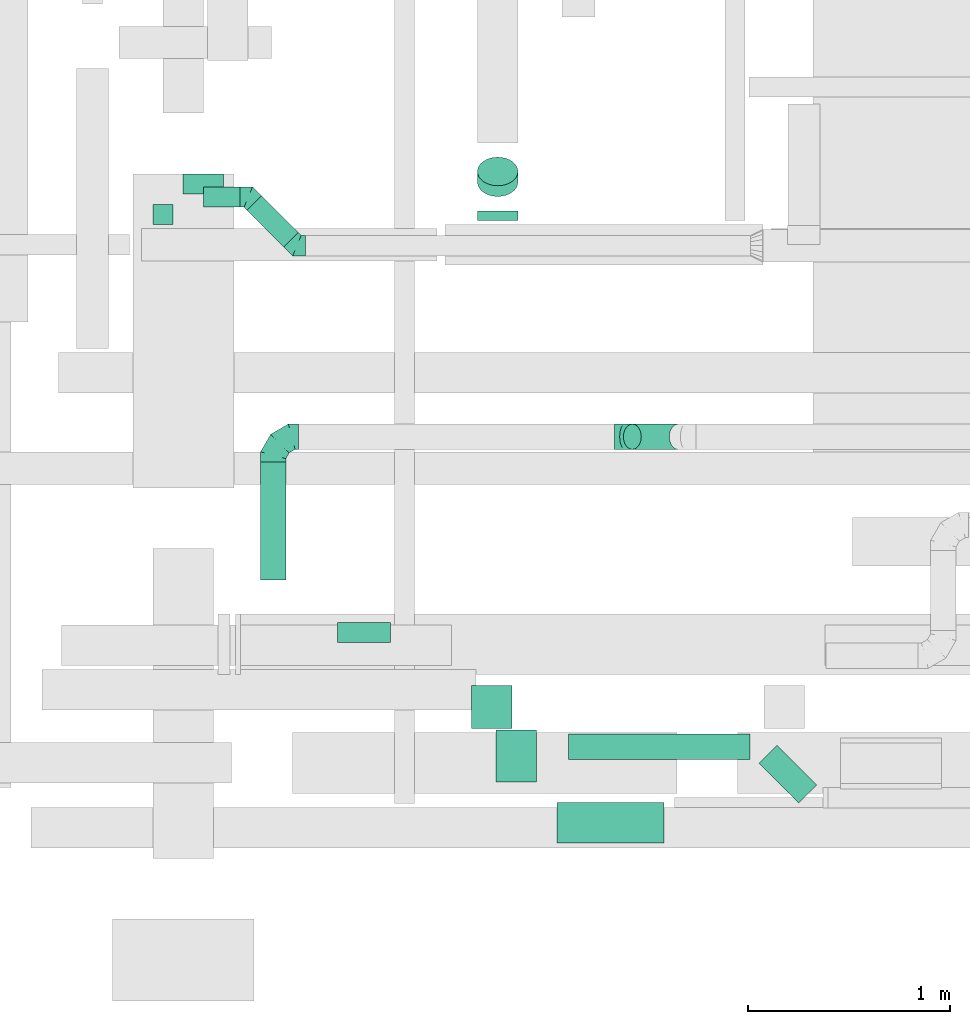
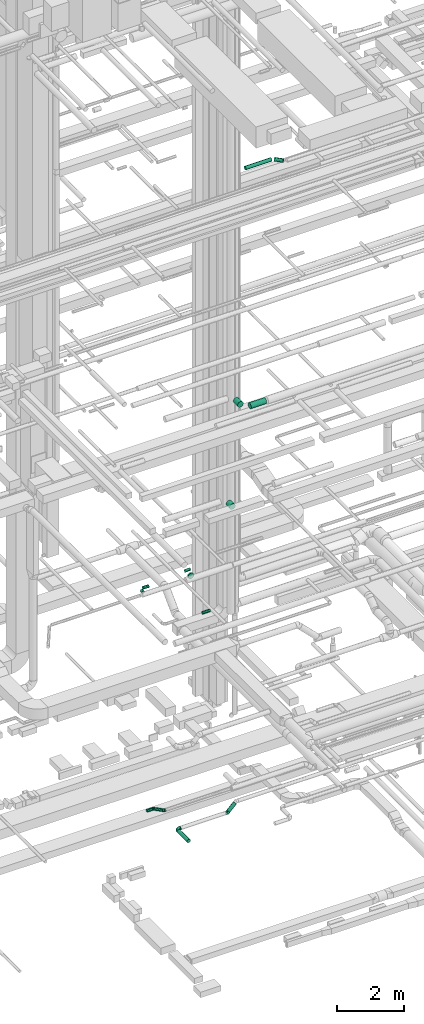
# One storey, part 114 of 337: 14 flow segments, 4 flow fittings.
"""IFC2X3 building model written with IfcOpenShell, lengths in millimetres."""

from ifc_helpers import new_model, entity, si_unit, converted_unit, derived_unit, direction, frame, origin, origin_2d_with_axis, place, context, subcontext, project, spatial, circle, extrude, faceted_brep, source, transform, mapped, material, type_object, type_shapes, element, save


model = new_model("IFC2X3")

# Units and contexts
model_context = context("Model", 3, precision=0.01, world=origin(), true_north=direction((6.12303176911189e-17, 1.0)))
body_context = subcontext(model_context, "Body", "Model", "MODEL_VIEW")
ifc_project = project(units=[si_unit("LENGTHUNIT", "METRE", prefix="MILLI"), si_unit("AREAUNIT", "SQUARE_METRE"), si_unit("VOLUMEUNIT", "CUBIC_METRE"), converted_unit("PLANEANGLEUNIT", "DEGREE", entity("IfcRatioMeasure", 0.0174532925199433), si_unit("PLANEANGLEUNIT", "RADIAN"), dimensions=[0, 0, 0, 0, 0, 0, 0]), si_unit("MASSUNIT", "GRAM", prefix="KILO"), derived_unit("MASSDENSITYUNIT", [(si_unit("MASSUNIT", "GRAM", prefix="KILO"), 1), (si_unit("LENGTHUNIT", "METRE"), -3)]), derived_unit("MOMENTOFINERTIAUNIT", [(si_unit("LENGTHUNIT", "METRE"), 4)]), si_unit("TIMEUNIT", "SECOND"), si_unit("FREQUENCYUNIT", "HERTZ"), si_unit("THERMODYNAMICTEMPERATUREUNIT", "DEGREE_CELSIUS"), derived_unit("THERMALTRANSMITTANCEUNIT", [(si_unit("MASSUNIT", "GRAM", prefix="KILO"), 1), (si_unit("THERMODYNAMICTEMPERATUREUNIT", "KELVIN"), -1), (si_unit("TIMEUNIT", "SECOND"), -3)]), derived_unit("VOLUMETRICFLOWRATEUNIT", [(si_unit("LENGTHUNIT", "METRE"), 3), (si_unit("TIMEUNIT", "SECOND"), -1)]), derived_unit("MASSFLOWRATEUNIT", [(si_unit("MASSUNIT", "GRAM", prefix="KILO"), 1), (si_unit("TIMEUNIT", "SECOND"), -1)]), derived_unit("ROTATIONALFREQUENCYUNIT", [(si_unit("TIMEUNIT", "SECOND"), -1)]), si_unit("ELECTRICCURRENTUNIT", "AMPERE"), si_unit("ELECTRICVOLTAGEUNIT", "VOLT"), si_unit("POWERUNIT", "WATT"), si_unit("FORCEUNIT", "NEWTON", prefix="KILO"), si_unit("ILLUMINANCEUNIT", "LUX"), si_unit("LUMINOUSFLUXUNIT", "LUMEN"), si_unit("LUMINOUSINTENSITYUNIT", "CANDELA"), derived_unit("USERDEFINED", [(si_unit("MASSUNIT", "GRAM", prefix="KILO"), -1), (si_unit("LENGTHUNIT", "METRE"), -2), (si_unit("TIMEUNIT", "SECOND"), 3), (si_unit("LUMINOUSFLUXUNIT", "LUMEN"), 1)]), derived_unit("LINEARVELOCITYUNIT", [(si_unit("LENGTHUNIT", "METRE"), 1), (si_unit("TIMEUNIT", "SECOND"), -1)]), si_unit("PRESSUREUNIT", "PASCAL"), derived_unit("USERDEFINED", [(si_unit("LENGTHUNIT", "METRE"), -2), (si_unit("MASSUNIT", "GRAM", prefix="KILO"), 1), (si_unit("TIMEUNIT", "SECOND"), -2)]), derived_unit("LINEARFORCEUNIT", [(si_unit("MASSUNIT", "GRAM", prefix="KILO"), 1), (si_unit("LENGTHUNIT", "METRE"), 1), (si_unit("TIMEUNIT", "SECOND"), -2), (si_unit("LENGTHUNIT", "METRE"), -1)]), derived_unit("PLANARFORCEUNIT", [(si_unit("MASSUNIT", "GRAM", prefix="KILO"), 1), (si_unit("LENGTHUNIT", "METRE"), 1), (si_unit("TIMEUNIT", "SECOND"), -2), (si_unit("LENGTHUNIT", "METRE"), -2)])], contexts=[model_context])

# Site, building, storey
site_placement = place(None, origin())
site = spatial("IfcSite", under=ifc_project, at=site_placement, CompositionType="ELEMENT")
building_placement = place(site_placement, origin())
building = spatial("IfcBuilding", under=site, at=building_placement, CompositionType="ELEMENT")
storey_placement = place(building_placement, origin())
storey = spatial("IfcBuildingStorey", under=building, at=storey_placement, CompositionType="ELEMENT", Elevation=0.0)

# Flow segments
duct_segment_type = type_object("IfcDuctSegmentType", PredefinedType="NOTDEFINED")
flow_segment_1_placement = place(storey_placement, frame((23591.76, 3480.54, 11248.4)))
element("IfcFlowSegment", 1, at=flow_segment_1_placement, inside=storey, type_object=duct_segment_type, context=body_context, shape_type="SweptSolid", body=[
    extrude(circle(Radius=50.0, at=origin_2d_with_axis()), frame((51.6, 0.0, 51.6), z_axis=(0.0, 1.0, 0.0), x_axis=(1.0, 0.0, 0.0)), (0.0, 0.0, 1.0), 100.0),
])
flow_segment_2_placement = place(storey_placement, frame((23743.35, 3628.95, 11248.4)))
element("IfcFlowSegment", 2, at=flow_segment_2_placement, inside=storey, type_object=duct_segment_type, context=body_context, shape_type="SweptSolid", body=[
    extrude(circle(Radius=50.0, at=origin_2d_with_axis()), frame((0.0, 51.6, 51.6), z_axis=(1.0, 0.0, 0.0), x_axis=(0.0, -1.0, 0.0)), (0.0, 0.0, 1.0), 200.000000000015),
])
flow_segment_3_placement = place(storey_placement, frame((24506.72, 1413.99, 11418.4)))
element("IfcFlowSegment", 3, at=flow_segment_3_placement, inside=storey, type_object=duct_segment_type, context=body_context, shape_type="SweptSolid", body=[
    extrude(circle(Radius=50.0, at=origin_2d_with_axis()), frame((0.0, 51.6, 51.6), z_axis=(1.0, 0.0, 0.0), x_axis=(0.0, 1.0, 0.0)), (0.0, 0.0, 1.0), 260.00000000017),
])
flow_segment_4_placement = place(storey_placement, frame((24124.11, 1724.63, 3085.9)))
element("IfcFlowSegment", 4, at=flow_segment_4_placement, inside=storey, type_object=duct_segment_type, context=body_context, shape_type="SweptSolid", body=[
    extrude(circle(Radius=62.5, at=origin_2d_with_axis()), frame((64.1, 0.0, 64.1), z_axis=(0.0, 1.0, 0.0), x_axis=(-1.0, 0.0, 0.0)), (0.0, 0.0, 1.0), 582.500000000018),
])
flow_segment_5_placement = place(storey_placement, frame((25916.58, 2368.04, 3140.82)))
element("IfcFlowSegment", 5, at=flow_segment_5_placement, inside=storey, type_object=duct_segment_type, context=body_context, shape_type="SweptSolid", body=[
    extrude(circle(Radius=62.5, at=origin_2d_with_axis()), frame((45.79, 64.1, 45.79), z_axis=(0.707106781186548, 0.0, 0.707106781186548), x_axis=(0.0, 1.0, 0.0)), (0.0, 0.0, 1.0), 320.710678118671),
])
flow_segment_6_placement = place(storey_placement, frame((24057.38, 3368.04, 3168.4)))
element("IfcFlowSegment", 6, at=flow_segment_6_placement, inside=storey, type_object=duct_segment_type, context=body_context, shape_type="SweptSolid", body=[
    extrude(circle(Radius=50.0, at=origin_2d_with_axis()), frame((36.95, 218.79, 51.6), z_axis=(0.707106781186518, -0.707106781186577, 0.0), x_axis=(0.707106781186577, 0.707106781186518, 0.0)), (0.0, 0.0, 1.0), 257.157287525386),
])
flow_segment_7_placement = place(storey_placement, frame((23845.05, 3564.52, 3168.4)))
element("IfcFlowSegment", 7, at=flow_segment_7_placement, inside=storey, type_object=duct_segment_type, context=body_context, shape_type="SweptSolid", body=[
    extrude(circle(Radius=50.0, at=origin_2d_with_axis()), frame((0.0, 51.6, 51.6), z_axis=(1.0, 0.0, 0.0), x_axis=(0.0, 1.0, 0.0)), (0.0, 0.0, 1.0), 178.578643762695),
])
flow_segment_8_placement = place(storey_placement, frame((25590.05, 424.22, 19073.4)))
element("IfcFlowSegment", 8, at=flow_segment_8_placement, inside=storey, type_object=duct_segment_type, context=body_context, shape_type="SweptSolid", body=[
    extrude(circle(Radius=100.0, at=origin_2d_with_axis()), frame((0.0, 101.6, 101.6), z_axis=(1.0, 0.0, 0.0), x_axis=(0.0, 1.0, 0.0)), (0.0, 0.0, 1.0), 529.687500000004),
])
flow_segment_9_placement = place(storey_placement, frame((25288.45, 725.82, 19073.4)))
element("IfcFlowSegment", 9, at=flow_segment_9_placement, inside=storey, type_object=duct_segment_type, context=body_context, shape_type="SweptSolid", body=[
    extrude(circle(Radius=100.0, at=origin_2d_with_axis()), frame((101.6, 0.0, 101.6), z_axis=(0.0, 1.0, 0.0), x_axis=(1.0, 0.0, 0.0)), (0.0, 0.0, 1.0), 257.499999999934),
])
flow_segment_10_placement = place(storey_placement, frame((25195.7, 3500.54, 11198.4)))
element("IfcFlowSegment", 10, at=flow_segment_10_placement, inside=storey, type_object=duct_segment_type, context=body_context, shape_type="SweptSolid", body=[
    extrude(circle(Radius=100.0, at=origin_2d_with_axis()), frame((101.6, 0.0, 101.6), z_axis=(0.0, 1.0, 0.0), x_axis=(1.0, 0.0, 0.0)), (0.0, 0.0, 1.0), 47.8768461773679),
])
flow_segment_11_placement = place(storey_placement, frame((25195.7, 3617.53, 11286.27)))
element("IfcFlowSegment", 11, at=flow_segment_11_placement, inside=storey, type_object=duct_segment_type, context=body_context, shape_type="SweptSolid", body=[
    extrude(circle(Radius=100.0, at=origin_2d_with_axis()), frame((101.6, 72.31, 72.31), z_axis=(0.0, 0.707106285379355, 0.707107276993392), x_axis=(1.0, 0.0, 0.0)), (0.0, 0.0, 1.0), 74.7305477839851),
])
flow_segment_12_placement = place(storey_placement, frame((25167.35, 990.66, 15248.4)))
element("IfcFlowSegment", 12, at=flow_segment_12_placement, inside=storey, type_object=duct_segment_type, context=body_context, shape_type="SweptSolid", body=[
    extrude(circle(Radius=100.0, at=origin_2d_with_axis()), frame((101.6, 0.0, 101.6), z_axis=(0.0, 1.0, 0.0), x_axis=(-1.0, 0.0, 0.0)), (0.0, 0.0, 1.0), 211.742634044861),
])
flow_segment_13_placement = place(storey_placement, frame((26587.24, 621.5, 27485.9)))
element("IfcFlowSegment", 13, at=flow_segment_13_placement, inside=storey, type_object=duct_segment_type, context=body_context, shape_type="SweptSolid", body=[
    extrude(circle(Radius=62.5, at=origin_2d_with_axis()), frame((45.79, 242.12, 64.1), z_axis=(0.707106781186528, -0.707106781186567, 0.0), x_axis=(0.707106781186567, 0.707106781186528, 0.0)), (0.0, 0.0, 1.0), 277.659812842335),
])
flow_segment_14_placement = place(storey_placement, frame((25646.42, 836.14, 27485.9)))
element("IfcFlowSegment", 14, at=flow_segment_14_placement, inside=storey, type_object=duct_segment_type, context=body_context, shape_type="SweptSolid", body=[
    extrude(circle(Radius=62.5, at=origin_2d_with_axis()), frame((0.0, 64.1, 64.1), z_axis=(1.0, 0.0, 0.0), x_axis=(0.0, 1.0, 0.0)), (0.0, 0.0, 1.0), 898.223304703355),
])

# Flow fittings
ifc_material = material()
duct_fitting_type_1 = type_object("IfcDuctFittingType", PredefinedType="NOTDEFINED", material=ifc_material)
shared_shape_1 = source(origin(), body_context, "Body", "Brep", [
    faceted_brep([(-125.0, 0.0, -62.5), (-125.0, -16.18, -60.37), (-125.0, -31.25, -54.13), (-125.0, -44.19, -44.19), (-125.0, -54.13, -31.25), (-125.0, -60.37, -16.18), (-125.0, -62.5, 0.0), (-125.0, -60.37, 16.18), (-125.0, -54.13, 31.25), (-125.0, -44.19, 44.19), (-125.0, -31.25, 54.13), (-125.0, -16.18, 60.37), (-125.0, 0.0, 62.5), (-125.0, 16.18, 60.37), (-125.0, 31.25, 54.13), (-125.0, 44.19, 44.19), (-125.0, 54.13, 31.25), (-125.0, 60.37, 16.18), (-125.0, 62.5, 0.0), (-125.0, 60.37, -16.18), (-125.0, 54.13, -31.25), (-125.0, 44.19, -44.19), (-125.0, 31.25, -54.13), (-125.0, 16.18, -60.37), (-95.84, 16.18, 60.37), (-99.88, 31.25, 54.13), (-91.51, 0.0, 62.5), (-103.35, 44.19, 44.19), (-107.68, 60.37, 16.18), (-108.25, 62.5, 0.0), (-106.01, 54.13, 31.25), (-106.01, 54.13, -31.25), (-103.35, 44.19, -44.19), (-107.68, 60.37, -16.18), (-95.84, 16.18, -60.37), (-91.51, 0.0, -62.5), (-99.88, 31.25, -54.13), (-87.17, -16.18, -60.37), (-83.13, -31.25, -54.13), (-79.66, -44.19, -44.19), (-77.0, -54.13, -31.25), (-75.33, -60.37, -16.18), (-74.76, -62.5, 0.0), (-75.33, -60.37, 16.18), (-77.0, -54.13, 31.25), (-79.66, -44.19, 44.19), (-83.13, -31.25, 54.13), (-87.17, -16.18, 60.37), (-45.34, 45.34, 60.37), (-56.37, 56.37, 54.13), (-33.49, 33.49, 62.5), (-65.85, 65.85, 44.19), (-73.12, 73.12, 31.25), (-77.69, 77.69, 16.18), (-79.25, 79.25, 0.0), (-77.69, 77.69, -16.18), (-73.12, 73.12, -31.25), (-65.85, 65.85, -44.19), (-45.34, 45.34, -60.37), (-33.49, 33.49, -62.5), (-56.37, 56.37, -54.13), (-21.65, 21.65, -60.37), (-10.62, 10.62, -54.13), (-1.14, 1.14, -44.19), (6.13, -6.13, -31.25), (10.7, -10.7, -16.18), (12.26, -12.26, 0.0), (10.7, -10.7, 16.18), (6.13, -6.13, 31.25), (-1.14, 1.14, 44.19), (-10.62, 10.62, 54.13), (-21.65, 21.65, 60.37), (-16.18, 95.84, 60.37), (-31.25, 99.88, 54.13), (0.0, 91.51, 62.5), (-44.19, 103.35, 44.19), (-54.13, 106.01, 31.25), (-60.37, 107.68, 16.18), (-62.5, 108.25, 0.0), (-60.37, 107.68, -16.18), (-54.13, 106.01, -31.25), (-44.19, 103.35, -44.19), (-16.18, 95.84, -60.37), (0.0, 91.51, -62.5), (-31.25, 99.88, -54.13), (16.18, 87.17, -60.37), (31.25, 83.13, -54.13), (44.19, 79.66, -44.19), (54.13, 77.0, -31.25), (60.37, 75.33, -16.18), (62.5, 74.76, 0.0), (60.37, 75.33, 16.18), (54.13, 77.0, 31.25), (44.19, 79.66, 44.19), (31.25, 83.13, 54.13), (16.18, 87.17, 60.37), (-16.18, 125.0, -60.37), (-31.25, 125.0, -54.13), (-44.19, 125.0, -44.19), (-54.13, 125.0, -31.25), (-60.37, 125.0, -16.18), (-62.5, 125.0, 0.0), (-60.37, 125.0, 16.18), (-54.13, 125.0, 31.25), (-44.19, 125.0, 44.19), (-31.25, 125.0, 54.13), (-16.18, 125.0, 60.37), (0.0, 125.0, 62.5), (16.18, 125.0, 60.37), (31.25, 125.0, 54.13), (44.19, 125.0, 44.19), (54.13, 125.0, 31.25), (60.37, 125.0, 16.18), (62.5, 125.0, 0.0), (60.37, 125.0, -16.18), (54.13, 125.0, -31.25), (44.19, 125.0, -44.19), (31.25, 125.0, -54.13), (16.18, 125.0, -60.37), (0.0, 125.0, -62.5)], [[[0, 1, 2, 3, 4, 5, 6, 7, 8, 9, 10, 11, 12, 13, 14, 15, 16, 17, 18, 19, 20, 21, 22, 23]], [[24, 25, 14, 13]], [[26, 24, 13, 12]], [[14, 25, 27, 15]], [[28, 29, 18, 17]], [[30, 28, 17, 16]], [[15, 27, 30, 16]], [[20, 31, 32, 21]], [[33, 31, 20, 19]], [[18, 29, 33, 19]], [[34, 35, 0, 23]], [[36, 34, 23, 22]], [[21, 32, 36, 22]], [[1, 0, 35, 37]], [[2, 1, 37, 38]], [[38, 39, 3, 2]], [[5, 4, 40, 41]], [[6, 5, 41, 42]], [[39, 40, 4, 3]], [[6, 42, 43, 7]], [[7, 43, 44, 8]], [[45, 9, 8, 44]], [[9, 45, 46, 10]], [[10, 46, 47, 11]], [[26, 12, 11, 47]], [[48, 49, 25, 24]], [[50, 48, 24, 26]], [[27, 25, 49, 51]], [[52, 53, 28, 30]], [[51, 52, 30, 27]], [[29, 28, 53, 54]], [[55, 56, 31, 33]], [[54, 55, 33, 29]], [[57, 32, 31, 56]], [[58, 59, 35, 34]], [[60, 58, 34, 36]], [[57, 60, 36, 32]], [[37, 35, 59, 61]], [[38, 37, 61, 62]], [[39, 38, 62, 63]], [[41, 40, 64, 65]], [[42, 41, 65, 66]], [[63, 64, 40, 39]], [[43, 42, 66, 67]], [[44, 43, 67, 68]], [[68, 69, 45, 44]], [[46, 45, 69, 70]], [[47, 46, 70, 71]], [[26, 47, 71, 50]], [[72, 73, 49, 48]], [[74, 72, 48, 50]], [[51, 49, 73, 75]], [[76, 77, 53, 52]], [[75, 76, 52, 51]], [[54, 53, 77, 78]], [[79, 80, 56, 55]], [[78, 79, 55, 54]], [[81, 57, 56, 80]], [[82, 83, 59, 58]], [[84, 82, 58, 60]], [[81, 84, 60, 57]], [[61, 59, 83, 85]], [[62, 61, 85, 86]], [[63, 62, 86, 87]], [[65, 64, 88, 89]], [[66, 65, 89, 90]], [[87, 88, 64, 63]], [[67, 66, 90, 91]], [[68, 67, 91, 92]], [[92, 93, 69, 68]], [[70, 69, 93, 94]], [[71, 70, 94, 95]], [[50, 71, 95, 74]], [[96, 97, 98, 99, 100, 101, 102, 103, 104, 105, 106, 107, 108, 109, 110, 111, 112, 113, 114, 115, 116, 117, 118, 119]], [[72, 74, 107, 106]], [[73, 72, 106, 105]], [[75, 73, 105, 104]], [[77, 76, 103, 102]], [[78, 77, 102, 101]], [[75, 104, 103, 76]], [[78, 101, 100, 79]], [[79, 100, 99, 80]], [[80, 99, 98, 81]], [[96, 119, 83, 82]], [[97, 96, 82, 84]], [[84, 81, 98, 97]], [[83, 119, 118, 85]], [[85, 118, 117, 86]], [[116, 87, 86, 117]], [[88, 115, 114, 89]], [[89, 114, 113, 90]], [[115, 88, 87, 116]], [[91, 90, 113, 112]], [[92, 91, 112, 111]], [[111, 110, 93, 92]], [[95, 94, 109, 108]], [[74, 95, 108, 107]], [[110, 109, 94, 93]]]),
])
type_shapes(duct_fitting_type_1, [shared_shape_1])
flow_fitting_1_placement = place(storey_placement, frame((24188.21, 2432.13, 3150.0), z_axis=(0.0, 0.0, 1.0), x_axis=(-1.0, 0.0, 0.0)))
element("IfcFlowFitting", 15, at=flow_fitting_1_placement, inside=storey, type_object=duct_fitting_type_1, material=ifc_material, context=body_context, shape_type="MappedRepresentation", body=[
    mapped(shared_shape_1, transform((0.0, 0.0, 0.0), scale=1.0)),
])
duct_fitting_type_2 = type_object("IfcDuctFittingType", PredefinedType="NOTDEFINED", material=ifc_material)
shared_shape_2 = source(origin(), body_context, "Body", "Brep", [
    faceted_brep([(-51.78, 0.0, -62.5), (-51.78, -16.18, -60.37), (-51.78, -31.25, -54.13), (-51.78, -44.19, -44.19), (-51.78, -54.13, -31.25), (-51.78, -60.37, -16.18), (-51.78, -62.5, 0.0), (-51.78, -60.37, 16.18), (-51.78, -54.13, 31.25), (-51.78, -44.19, 44.19), (-51.78, -31.25, 54.13), (-51.78, -16.18, 60.37), (-51.78, 0.0, 62.5), (-51.78, 16.18, 60.37), (-51.78, 31.25, 54.13), (-51.78, 44.19, 44.19), (-51.78, 54.13, 31.25), (-51.78, 60.37, 16.18), (-51.78, 62.5, 0.0), (-51.78, 60.37, -16.18), (-51.78, 54.13, -31.25), (-51.78, 44.19, -44.19), (-51.78, 31.25, -54.13), (-51.78, 16.18, -60.37), (-6.7, 16.18, 60.37), (-12.94, 31.25, 54.13), (0.0, 0.0, 62.5), (-18.31, 44.19, 44.19), (-22.42, 54.13, 31.25), (-25.01, 60.37, 16.18), (-25.89, 62.5, 0.0), (-25.01, 60.37, -16.18), (-22.42, 54.13, -31.25), (-18.31, 44.19, -44.19), (-6.7, 16.18, -60.37), (0.0, 0.0, -62.5), (-12.94, 31.25, -54.13), (6.7, -16.18, -60.37), (12.94, -31.25, -54.13), (18.31, -44.19, -44.19), (22.42, -54.13, -31.25), (25.01, -60.37, -16.18), (25.89, -62.5, 0.0), (25.01, -60.37, 16.18), (22.42, -54.13, 31.25), (18.31, -44.19, 44.19), (12.94, -31.25, 54.13), (6.7, -16.18, 60.37), (25.17, 48.05, 60.37), (14.51, 58.71, 54.13), (36.61, 36.61, 62.5), (5.36, 67.86, 44.19), (-1.66, 74.88, 31.25), (-6.08, 79.3, 16.18), (-7.58, 80.81, 0.0), (-6.08, 79.3, -16.18), (-1.66, 74.88, -31.25), (5.36, 67.86, -44.19), (14.51, 58.71, -54.13), (25.17, 48.05, -60.37), (36.61, 36.61, -62.5), (48.05, 25.17, -60.37), (58.71, 14.51, -54.13), (67.86, 5.36, -44.19), (74.88, -1.66, -31.25), (79.3, -6.08, -16.18), (80.81, -7.58, 0.0), (79.3, -6.08, 16.18), (74.88, -1.66, 31.25), (67.86, 5.36, 44.19), (58.71, 14.51, 54.13), (48.05, 25.17, 60.37)], [[[0, 1, 2, 3, 4, 5, 6, 7, 8, 9, 10, 11, 12, 13, 14, 15, 16, 17, 18, 19, 20, 21, 22, 23]], [[24, 25, 14, 13]], [[26, 24, 13, 12]], [[27, 15, 14, 25]], [[28, 29, 17, 16]], [[28, 16, 15, 27]], [[30, 18, 17, 29]], [[31, 32, 20, 19]], [[30, 31, 19, 18]], [[21, 20, 32, 33]], [[34, 35, 0, 23]], [[36, 34, 23, 22]], [[33, 36, 22, 21]], [[1, 0, 35, 37]], [[2, 1, 37, 38]], [[38, 39, 3, 2]], [[5, 4, 40, 41]], [[6, 5, 41, 42]], [[39, 40, 4, 3]], [[6, 42, 43, 7]], [[7, 43, 44, 8]], [[8, 44, 45, 9]], [[9, 45, 46, 10]], [[10, 46, 47, 11]], [[26, 12, 11, 47]], [[48, 49, 25, 24]], [[50, 48, 24, 26]], [[27, 25, 49, 51]], [[29, 28, 52, 53]], [[30, 29, 53, 54]], [[51, 52, 28, 27]], [[30, 54, 55, 31]], [[31, 55, 56, 32]], [[57, 33, 32, 56]], [[36, 58, 59, 34]], [[34, 59, 60, 35]], [[58, 36, 33, 57]], [[35, 60, 61, 37]], [[37, 61, 62, 38]], [[63, 39, 38, 62]], [[40, 64, 65, 41]], [[41, 65, 66, 42]], [[64, 40, 39, 63]], [[43, 42, 66, 67]], [[44, 43, 67, 68]], [[68, 69, 45, 44]], [[47, 46, 70, 71]], [[26, 47, 71, 50]], [[69, 70, 46, 45]], [[59, 58, 57, 56, 55, 54, 53, 52, 51, 49, 48, 50, 71, 70, 69, 68, 67, 66, 65, 64, 63, 62, 61, 60]]]),
])
type_shapes(duct_fitting_type_2, [shared_shape_2])
flow_fitting_2_placement = place(storey_placement, frame((25925.76, 2432.13, 3150.0), z_axis=(0.0, 1.0, 0.0), x_axis=(-0.707106781186526, 0.0, -0.707106781186569)))
element("IfcFlowFitting", 16, at=flow_fitting_2_placement, inside=storey, type_object=duct_fitting_type_2, material=ifc_material, context=body_context, shape_type="MappedRepresentation", body=[
    mapped(shared_shape_2, transform((0.0, 0.0, 0.0), scale=1.0)),
])
duct_fitting_type_3 = type_object("IfcDuctFittingType", PredefinedType="NOTDEFINED", material=ifc_material)
shared_shape_3 = source(origin(), body_context, "Body", "Brep", [
    faceted_brep([(-41.42, 0.0, -50.0), (-41.42, -12.94, -48.3), (-41.42, -25.0, -43.3), (-41.42, -35.36, -35.36), (-41.42, -43.3, -25.0), (-41.42, -48.3, -12.94), (-41.42, -50.0, 0.0), (-41.42, -48.3, 12.94), (-41.42, -43.3, 25.0), (-41.42, -35.36, 35.36), (-41.42, -25.0, 43.3), (-41.42, -12.94, 48.3), (-41.42, 0.0, 50.0), (-41.42, 12.94, 48.3), (-41.42, 25.0, 43.3), (-41.42, 35.36, 35.36), (-41.42, 43.3, 25.0), (-41.42, 48.3, 12.94), (-41.42, 50.0, 0.0), (-41.42, 48.3, -12.94), (-41.42, 43.3, -25.0), (-41.42, 35.36, -35.36), (-41.42, 25.0, -43.3), (-41.42, 12.94, -48.3), (-5.36, 12.94, 48.3), (-10.36, 25.0, 43.3), (0.0, 0.0, 50.0), (-14.64, 35.36, 35.36), (-20.0, 48.3, 12.94), (-20.71, 50.0, 0.0), (-17.94, 43.3, 25.0), (-17.94, 43.3, -25.0), (-14.64, 35.36, -35.36), (-20.0, 48.3, -12.94), (-5.36, 12.94, -48.3), (0.0, 0.0, -50.0), (-10.36, 25.0, -43.3), (5.36, -12.94, -48.3), (10.36, -25.0, -43.3), (14.64, -35.36, -35.36), (17.94, -43.3, -25.0), (20.0, -48.3, -12.94), (20.71, -50.0, 0.0), (20.0, -48.3, 12.94), (17.94, -43.3, 25.0), (14.64, -35.36, 35.36), (10.36, -25.0, 43.3), (5.36, -12.94, 48.3), (29.29, 29.29, 50.0), (20.14, 38.44, 48.3), (11.61, 46.97, 43.3), (4.29, 54.29, 35.36), (-1.33, 59.91, 25.0), (-4.86, 63.44, 12.94), (-6.07, 64.64, 0.0), (-4.86, 63.44, -12.94), (-1.33, 59.91, -25.0), (4.29, 54.29, -35.36), (11.61, 46.97, -43.3), (20.14, 38.44, -48.3), (29.29, 29.29, -50.0), (38.44, 20.14, -48.3), (46.97, 11.61, -43.3), (54.29, 4.29, -35.36), (59.91, -1.33, -25.0), (63.44, -4.86, -12.94), (64.64, -6.07, 0.0), (63.44, -4.86, 12.94), (59.91, -1.33, 25.0), (54.29, 4.29, 35.36), (46.97, 11.61, 43.3), (38.44, 20.14, 48.3)], [[[0, 1, 2, 3, 4, 5, 6, 7, 8, 9, 10, 11, 12, 13, 14, 15, 16, 17, 18, 19, 20, 21, 22, 23]], [[24, 25, 14, 13]], [[26, 24, 13, 12]], [[14, 25, 27, 15]], [[28, 29, 18, 17]], [[30, 28, 17, 16]], [[16, 15, 27, 30]], [[20, 31, 32, 21]], [[33, 31, 20, 19]], [[18, 29, 33, 19]], [[34, 35, 0, 23]], [[36, 34, 23, 22]], [[32, 36, 22, 21]], [[1, 0, 35, 37]], [[2, 1, 37, 38]], [[38, 39, 3, 2]], [[5, 4, 40, 41]], [[6, 5, 41, 42]], [[39, 40, 4, 3]], [[6, 42, 43, 7]], [[7, 43, 44, 8]], [[8, 44, 45, 9]], [[9, 45, 46, 10]], [[10, 46, 47, 11]], [[26, 12, 11, 47]], [[24, 26, 48, 49]], [[25, 24, 49, 50]], [[27, 25, 50, 51]], [[28, 30, 52, 53]], [[29, 28, 53, 54]], [[27, 51, 52, 30]], [[29, 54, 55, 33]], [[33, 55, 56, 31]], [[31, 56, 57, 32]], [[36, 58, 59, 34]], [[34, 59, 60, 35]], [[36, 32, 57, 58]], [[61, 62, 38, 37]], [[60, 61, 37, 35]], [[63, 39, 38, 62]], [[40, 64, 65, 41]], [[41, 65, 66, 42]], [[64, 40, 39, 63]], [[43, 42, 66, 67]], [[44, 43, 67, 68]], [[68, 69, 45, 44]], [[47, 46, 70, 71]], [[26, 47, 71, 48]], [[69, 70, 46, 45]], [[59, 58, 57, 56, 55, 54, 53, 52, 51, 50, 49, 48, 71, 70, 69, 68, 67, 66, 65, 64, 63, 62, 61, 60]]]),
])
type_shapes(duct_fitting_type_3, [shared_shape_3])
for number, where, z_axis, x_axis in (
    (17, (24305.46, 3375.7, 3220.0), (0.0, 0.0, 1.0), (0.70710678118654, -0.707106781186555, 0.0)),
    (18, (24065.05, 3616.12, 3220.0), (0.0, 0.0, 1.0), (-0.707106781186518, 0.707106781186577, 0.0)),
):
    element("IfcFlowFitting", number, at=place(storey_placement, frame(where, z_axis=z_axis, x_axis=x_axis)), inside=storey, type_object=duct_fitting_type_3, material=ifc_material, context=body_context, shape_type="MappedRepresentation", body=[
        mapped(shared_shape_3, transform((0.0, 0.0, 0.0), scale=1.0)),
    ])

save(model, "model.ifc")
